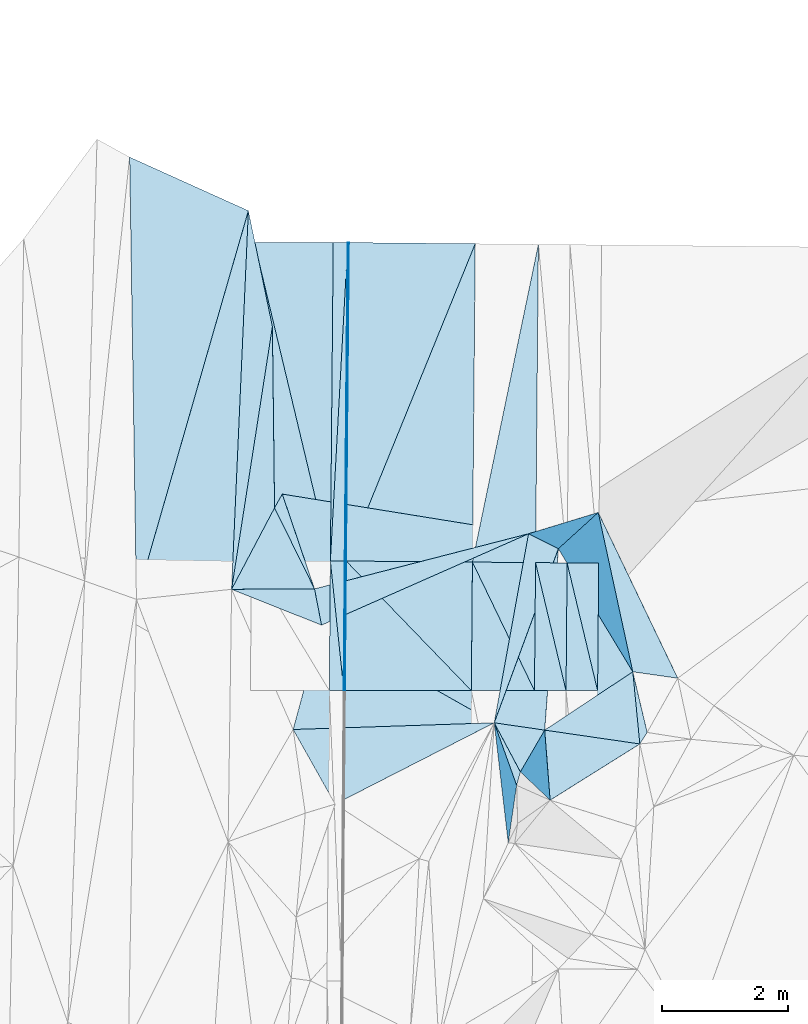
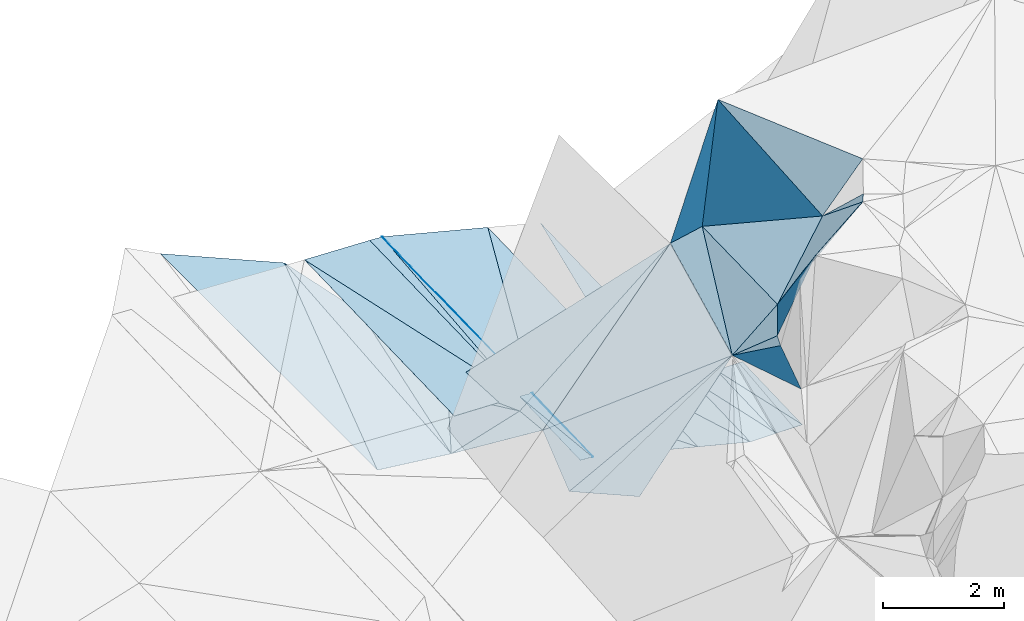
# One storey, part 161 of 275: 46 plates.
"""IFC2X3 building model written with IfcOpenShell, lengths in millimetres."""

from ifc_helpers import new_model, si_unit, frame, origin_with_axes, place, context, subcontext, project, spatial, polyline, outline, extrude, material, type_object, element, save


model = new_model("IFC2X3")

# Units and contexts
model_context = context("Model", 3, precision=1e-05, world=origin_with_axes())
body_context = subcontext(model_context, "Body", "Model", "MODEL_VIEW")
ifc_project = project(units=[si_unit("LENGTHUNIT", "METRE", prefix="MILLI"), si_unit("AREAUNIT", "SQUARE_METRE"), si_unit("VOLUMEUNIT", "CUBIC_METRE"), si_unit("MASSUNIT", "GRAM", prefix="KILO"), si_unit("TIMEUNIT", "SECOND"), si_unit("PLANEANGLEUNIT", "RADIAN"), si_unit("SOLIDANGLEUNIT", "STERADIAN"), si_unit("THERMODYNAMICTEMPERATUREUNIT", "DEGREE_CELSIUS"), si_unit("LUMINOUSINTENSITYUNIT", "LUMEN")], contexts=[model_context])

# Site, building, storey
site_placement = place(None, origin_with_axes())
site = spatial("IfcSite", under=ifc_project, at=site_placement, CompositionType="ELEMENT")
building_placement = place(site_placement, origin_with_axes())
building = spatial("IfcBuilding", under=site, at=building_placement, Name="Undefined", CompositionType="ELEMENT")
storey_placement = place(building_placement, origin_with_axes())
storey = spatial("IfcBuildingStorey", under=building, at=storey_placement, Name="Undefined", CompositionType="ELEMENT", Elevation=0.0)

# Plates
ifc_material = material()
plate_type_1 = type_object("IfcPlateType", PredefinedType="NOTDEFINED")
plate_1_placement = place(storey_placement, frame((-53921.4130209684, 132875.767032502, 43040.4130466603), z_axis=(-0.242290097947549, 0.0238708479118804, -0.969910145867407), x_axis=(-0.970181049799979, 0.000892282855675396, 0.242379731909076)))
element("IfcPlate", 1, at=plate_1_placement, inside=storey, type_object=plate_type_1, material=ifc_material, Name="00_PR", context=body_context, shape_type="SweptSolid", body=[
    extrude(outline(polyline([(0.0, 0.0), (2061.525390625, -3.63797880709171e-09), (2057.89990234375, 2051.69555664063), (0.0, 0.0)])), frame((-8.85201319254618e-08, 2.18876761149539e-07, -0.5000001331573), z_axis=(0.0, 0.0, 1.0), x_axis=(1.0, 0.0, 0.0)), (0.0, 0.0, 1.0), 1.0),
])
plate_type_2 = type_object("IfcPlateType", PredefinedType="NOTDEFINED")
plate_2_placement = place(storey_placement, frame((-55904.2060124232, 134928.710053341, 43586.2636953464), z_axis=(-0.0497725011782063, 0.0172078240274275, -0.998612331647625), x_axis=(0.00499603186977933, 0.999843346921011, 0.0169800260114044)))
element("IfcPlate", 2, at=plate_2_placement, inside=storey, type_object=plate_type_2, material=ifc_material, Name="00_PR", context=body_context, shape_type="SweptSolid", body=[
    extrude(outline(polyline([(0.0, 0.0), (5045.751953125, -6.52726157568395e-08), (5045.6474609375, 20.0242309570313), (0.0, 0.0)])), frame((-8.85201319254618e-08, 2.18876761149539e-07, -0.5000001331573), z_axis=(0.0, 0.0, 1.0), x_axis=(1.0, 0.0, 0.0)), (0.0, 0.0, 1.0), 1.0),
])
plate_3_placement = place(storey_placement, frame((-55921.3697174635, 132877.606016511, 43540.0707515838), z_axis=(-0.0497315401141636, 0.0229033836072573, -0.998499979437763), x_axis=(-0.00138182012259153, 0.999734497988441, 0.0230005240146595)))
element("IfcPlate", 3, at=plate_3_placement, inside=storey, type_object=plate_type_2, material=ifc_material, Name="00_PR", context=body_context, shape_type="SweptSolid", body=[
    extrude(outline(polyline([(0.0, 0.0), (2051.82275390625, -1.82699295692146e-08), (2051.60107421875, 20.0234661102295), (0.0, 0.0)])), frame((-8.85201319254618e-08, 2.18876761149539e-07, -0.5000001331573), z_axis=(0.0, 0.0, 1.0), x_axis=(1.0, 0.0, 0.0)), (0.0, 0.0, 1.0), 1.0),
])
plate_4_placement = place(storey_placement, frame((-55924.2049922256, 134928.881206525, 43587.2636961487), z_axis=(-0.0497854212460474, 0.0172078761853657, -0.998611686707372), x_axis=(0.00895964489837265, 0.99981902822702, 0.0167820010270476)))
element("IfcPlate", 4, at=plate_4_placement, inside=storey, type_object=plate_type_2, material=ifc_material, Name="00_PR", context=body_context, shape_type="SweptSolid", body=[
    extrude(outline(polyline([(0.0, 0.0), (5045.70361328125, -3.39423422701657e-08), (-0.00872510019689798, 20.0246906280518), (0.0, 0.0)])), frame((-8.85201319254618e-08, 2.18876761149539e-07, -0.5000001331573), z_axis=(0.0, 0.0, 1.0), x_axis=(1.0, 0.0, 0.0)), (0.0, 0.0, 1.0), 1.0),
])
plate_5_placement = place(storey_placement, frame((-55941.3701169843, 132877.624564946, 43541.0677525396), z_axis=(-0.0497529466740332, 0.0229033298257444, -0.998498914260874), x_axis=(0.00836568591627843, 0.999711519163658, 0.0225143010249118)))
element("IfcPlate", 5, at=plate_5_placement, inside=storey, type_object=plate_type_2, material=ifc_material, Name="00_PR", context=body_context, shape_type="SweptSolid", body=[
    extrude(outline(polyline([(0.0, 0.0), (2051.85131835938, 7.93079379945993e-10), (0.126321852207184, 20.0248374938965), (0.0, 0.0)])), frame((-8.85201319254618e-08, 2.18876761149539e-07, -0.5000001331573), z_axis=(0.0, 0.0, 1.0), x_axis=(1.0, 0.0, 0.0)), (0.0, 0.0, 1.0), 1.0),
])
plate_type_3 = type_object("IfcPlateType", PredefinedType="NOTDEFINED")
plate_6_placement = place(storey_placement, frame((-52904.4115996075, 134903.095372092, 42836.2780461026), z_axis=(-0.242282814206146, 0.0238821500295382, -0.969911687139771), x_axis=(-0.00836740889175489, -0.999711247153736, -0.0225257360092888)))
element("IfcPlate", 6, at=plate_6_placement, inside=storey, type_object=plate_type_3, material=ifc_material, Name="00_PR", context=body_context, shape_type="SweptSolid", body=[
    extrude(outline(polyline([(0.0, 0.0), (2028.8349609375, -1.53013388626277e-08), (-5.80120325088501, 1030.76013183594), (0.0, 0.0)])), frame((-8.85201319254618e-08, 2.18876761149539e-07, -0.5000001331573), z_axis=(0.0, 0.0, 1.0), x_axis=(1.0, 0.0, 0.0)), (0.0, 0.0, 1.0), 1.0),
])
plate_type_4 = type_object("IfcPlateType", PredefinedType="NOTDEFINED")
plate_7_placement = place(storey_placement, frame((-56108.9794554102, 139975.828901893, 43683.440374112), z_axis=(-0.0345822401341188, 0.0170818079940754, -0.999255863381827), x_axis=(-0.00895964489279158, -0.999819028227098, -0.0167820010254024)))
element("IfcPlate", 7, at=plate_7_placement, inside=storey, type_object=plate_type_4, material=ifc_material, Name="00_PR", context=body_context, shape_type="SweptSolid", body=[
    extrude(outline(polyline([(0.0, 0.0), (5045.89697265625, 2.19661160372198e-08), (9.51279067993164, 1250.75866699219), (0.0, 0.0)])), frame((-8.85201319254618e-08, 2.18876761149539e-07, -0.5000001331573), z_axis=(0.0, 0.0, 1.0), x_axis=(1.0, 0.0, 0.0)), (0.0, 0.0, 1.0), 1.0),
])
plate_type_5 = type_object("IfcPlateType", PredefinedType="NOTDEFINED")
plate_8_placement = place(storey_placement, frame((-51904.3262961077, 134894.556678768, 42836.2631288285), z_axis=(0.000192357398170822, 0.0225286831170885, -0.999746178505145), x_axis=(-0.00836798991196483, -0.99971115738236, -0.0225295039904336)))
element("IfcPlate", 8, at=plate_8_placement, inside=storey, type_object=plate_type_5, material=ifc_material, Name="00_PR", context=body_context, shape_type="SweptSolid", body=[
    extrude(outline(polyline([(0.0, 0.0), (2021.21618652344, -1.95432221516967e-08), (-0.0839325413107872, 500.000244140625), (0.0, 0.0)])), frame((-8.85201319254618e-08, 2.18876761149539e-07, -0.5000001331573), z_axis=(0.0, 0.0, 1.0), x_axis=(1.0, 0.0, 0.0)), (0.0, 0.0, 1.0), 1.0),
])
plate_9_placement = place(storey_placement, frame((-52404.308328989, 134898.825689368, 42836.2631288407), z_axis=(0.000192341308816795, 0.0225268031947438, -0.9997462208694), x_axis=(-0.0083675759069814, -0.999711203213438, -0.0225276239977039)))
element("IfcPlate", 9, at=plate_9_placement, inside=storey, type_object=plate_type_5, material=ifc_material, Name="00_PR", context=body_context, shape_type="SweptSolid", body=[
    extrude(outline(polyline([(0.0, 0.0), (2025.02490234375, -1.42608769237995e-08), (-0.0841391012072563, 500.000244140625), (0.0, 0.0)])), frame((-8.85201319254618e-08, 2.18876761149539e-07, -0.5000001331573), z_axis=(0.0, 0.0, 1.0), x_axis=(1.0, 0.0, 0.0)), (0.0, 0.0, 1.0), 1.0),
])
plate_type_6 = type_object("IfcPlateType", PredefinedType="NOTDEFINED")
plate_10_placement = place(storey_placement, frame((-55878.9972813765, 139973.671639461, 43671.9406962223), z_axis=(-0.0497854212460474, 0.0172078761853657, -0.998611686707372), x_axis=(-0.00895964489279158, -0.999819028227098, -0.0167820010254024)))
element("IfcPlate", 10, at=plate_10_placement, inside=storey, type_object=plate_type_6, material=ifc_material, Name="00_PR", context=body_context, shape_type="SweptSolid", body=[
    extrude(outline(polyline([(0.0, 0.0), (5045.70361328125, -3.39423422701657e-08), (5045.607421875, 230.287475585938), (0.0, 0.0)])), frame((-8.85201319254618e-08, 2.18876761149539e-07, -0.5000001331573), z_axis=(0.0, 0.0, 1.0), x_axis=(1.0, 0.0, 0.0)), (0.0, 0.0, 1.0), 1.0),
])
plate_11_placement = place(storey_placement, frame((-56154.1967670006, 134930.845211354, 43598.7636957895), z_axis=(-0.0497714340509185, 0.0172071230381387, -0.99861239691347), x_axis=(0.00895964489837265, 0.99981902822702, 0.0167820010270476)))
element("IfcPlate", 11, at=plate_11_placement, inside=storey, type_object=plate_type_6, material=ifc_material, Name="00_PR", context=body_context, shape_type="SweptSolid", body=[
    extrude(outline(polyline([(0.0, 0.0), (5045.89697265625, 2.19661160372198e-08), (5045.607421875, 230.287033081055), (0.0, 0.0)])), frame((-8.85201319254618e-08, 2.18876761149539e-07, -0.5000001331573), z_axis=(0.0, 0.0, 1.0), x_axis=(1.0, 0.0, 0.0)), (0.0, 0.0, 1.0), 1.0),
])
plate_type_7 = type_object("IfcPlateType", PredefinedType="NOTDEFINED")
plate_12_placement = place(storey_placement, frame((-56405.4393574782, 134486.97513791, 43659.5220884119), z_axis=(0.29267855635156, -0.0269160163758398, -0.955831988748243), x_axis=(-0.956205391673312, -0.00484916303644232, -0.292656342068191)))
element("IfcPlate", 12, at=plate_12_placement, inside=storey, type_object=plate_type_7, material=ifc_material, Name="00", context=body_context, shape_type="SweptSolid", body=[
    extrude(outline(polyline([(0.0, 0.0), (1373.62475585938, 3.34694050252438e-09), (666.448364257813, 1287.34094238281), (0.0, 0.0)])), frame((-8.85201319254618e-08, 2.18876761149539e-07, -0.5000001331573), z_axis=(0.0, 0.0, 1.0), x_axis=(1.0, 0.0, 0.0)), (0.0, 0.0, 1.0), 1.0),
])
plate_type_8 = type_object("IfcPlateType", PredefinedType="NOTDEFINED")
plate_13_placement = place(storey_placement, frame((-52859.2261846876, 139945.336646448, 42920.954995991), z_axis=(-0.242354222271301, 0.0184617411486156, -0.970012162326347), x_axis=(-0.00895975488317066, -0.999818885003066, -0.016790473002845)))
element("IfcPlate", 13, at=plate_13_placement, inside=storey, type_object=plate_type_8, material=ifc_material, Name="00_PR", context=body_context, shape_type="SweptSolid", body=[
    extrude(outline(polyline([(0.0, 0.0), (5043.1572265625, 7.13480403646827e-08), (5039.38134765625, 1030.76953125), (0.0, 0.0)])), frame((-8.85201319254618e-08, 2.18876761149539e-07, -0.5000001331573), z_axis=(0.0, 0.0, 1.0), x_axis=(1.0, 0.0, 0.0)), (0.0, 0.0, 1.0), 1.0),
])
plate_type_9 = type_object("IfcPlateType", PredefinedType="NOTDEFINED")
plate_14_placement = place(storey_placement, frame((-55924.2049667567, 134928.884053921, 43587.2637520365), z_axis=(-0.0497315401141636, 0.0229033836072573, -0.998499979437763), x_axis=(-0.00836568588378333, -0.999711519163901, -0.0225143010262109)))
element("IfcPlate", 14, at=plate_14_placement, inside=storey, type_object=plate_type_9, material=ifc_material, Name="00_PR", context=body_context, shape_type="SweptSolid", body=[
    extrude(outline(polyline([(0.0, 0.0), (2051.85131835938, 7.93079379945993e-10), (-0.298315227031708, 230.287292480469), (0.0, 0.0)])), frame((-8.85201319254618e-08, 2.18876761149539e-07, -0.5000001331573), z_axis=(0.0, 0.0, 1.0), x_axis=(1.0, 0.0, 0.0)), (0.0, 0.0, 1.0), 1.0),
])
plate_15_placement = place(storey_placement, frame((-56171.3751850407, 132877.835496, 43552.5297522885), z_axis=(-0.0497379128704129, 0.0229024672686787, -0.99849968303265), x_axis=(0.00836501392567888, 0.999711541024091, 0.0225135800187272)))
element("IfcPlate", 15, at=plate_15_placement, inside=storey, type_object=plate_type_9, material=ifc_material, Name="00_PR", context=body_context, shape_type="SweptSolid", body=[
    extrude(outline(polyline([(0.0, 0.0), (2053.60498046875, 1.96523615159094e-08), (1.455073595047, 230.285995483398), (0.0, 0.0)])), frame((-8.85201319254618e-08, 2.18876761149539e-07, -0.5000001331573), z_axis=(0.0, 0.0, 1.0), x_axis=(1.0, 0.0, 0.0)), (0.0, 0.0, 1.0), 1.0),
])
plate_type_10 = type_object("IfcPlateType", PredefinedType="NOTDEFINED")
plate_16_placement = place(storey_placement, frame((-52421.2528831777, 132874.38557646, 42790.6441287965), z_axis=(0.000184737649818864, 0.0225268668452634, -0.999746220869145), x_axis=(0.00836757589274174, 0.999711203213378, 0.0225276240056514)))
element("IfcPlate", 16, at=plate_16_placement, inside=storey, type_object=plate_type_10, material=ifc_material, Name="00_PR", context=body_context, shape_type="SweptSolid", body=[
    extrude(outline(polyline([(0.0, 0.0), (2025.02490234375, -1.42608769237995e-08), (3.72456526756287, 499.999420166016), (0.0, 0.0)])), frame((-8.85201319254618e-08, 2.18876761149539e-07, -0.5000001331573), z_axis=(0.0, 0.0, 1.0), x_axis=(1.0, 0.0, 0.0)), (0.0, 0.0, 1.0), 1.0),
])
plate_17_placement = place(storey_placement, frame((-52921.2664574846, 132874.845568885, 42790.5621287736), z_axis=(0.000184676063021724, 0.022524979296584, -0.999746263410092), x_axis=(0.00836740888687607, 0.9997112471538, 0.0225257360082723)))
element("IfcPlate", 17, at=plate_17_placement, inside=storey, type_object=plate_type_10, material=ifc_material, Name="00_PR", context=body_context, shape_type="SweptSolid", body=[
    extrude(outline(polyline([(0.0, 0.0), (2028.8349609375, -1.53013388626277e-08), (3.72580480575562, 499.999908447266), (0.0, 0.0)])), frame((-8.85201319254618e-08, 2.18876761149539e-07, -0.5000001331573), z_axis=(0.0, 0.0, 1.0), x_axis=(1.0, 0.0, 0.0)), (0.0, 0.0, 1.0), 1.0),
])
plate_type_11 = type_object("IfcPlateType", PredefinedType="NOTDEFINED")
plate_18_placement = place(storey_placement, frame((-53859.1819873665, 139954.719111887, 43170.9549940225), z_axis=(-0.242341293143886, 0.0184534773975507, -0.970015549777058), x_axis=(-0.375800488034076, -0.923552718411648, 0.0763175570088952)))
element("IfcPlate", 18, at=plate_18_placement, inside=storey, type_object=plate_type_11, material=ifc_material, Name="00_PR", context=body_context, shape_type="SweptSolid", body=[
    extrude(outline(polyline([(0.0, 0.0), (5442.03759765625, 5.18339220434427e-08), (772.396179199219, 1911.38903808594), (0.0, 0.0)])), frame((-8.85201319254618e-08, 2.18876761149539e-07, -0.5000001331573), z_axis=(0.0, 0.0, 1.0), x_axis=(1.0, 0.0, 0.0)), (0.0, 0.0, 1.0), 1.0),
])
plate_19_placement = place(storey_placement, frame((-53859.1819873665, 139954.719111887, 43170.9549940225), z_axis=(-0.242354256552694, 0.0184590281804045, -0.970012205391987), x_axis=(-0.00895979286870753, -0.999818931781245, -0.0167876670076637)))
element("IfcPlate", 19, at=plate_19_placement, inside=storey, type_object=plate_type_11, material=ifc_material, Name="00_PR", context=body_context, shape_type="SweptSolid", body=[
    extrude(outline(polyline([(0.0, 0.0), (5044.00048828125, 3.51283233612776e-08), (5036.44970703125, 2061.5390625), (0.0, 0.0)])), frame((-8.85201319254618e-08, 2.18876761149539e-07, -0.5000001331573), z_axis=(0.0, 0.0, 1.0), x_axis=(1.0, 0.0, 0.0)), (0.0, 0.0, 1.0), 1.0),
])
plate_type_12 = type_object("IfcPlateType", PredefinedType="NOTDEFINED")
plate_20_placement = place(storey_placement, frame((-55904.302267707, 134928.713389166, 43586.2780457261), z_axis=(-0.242282867316031, 0.0238782631497267, -0.96991176957189), x_axis=(0.970107128969726, -0.00828437587314537, -0.242535620968359)))
element("IfcPlate", 20, at=plate_20_placement, inside=storey, type_object=plate_type_12, material=ifc_material, Name="00_PR", context=body_context, shape_type="SweptSolid", body=[
    extrude(outline(polyline([(0.0, 0.0), (2061.552734375, -7.5924617704004e-09), (2073.01416015625, 2036.42321777344), (0.0, 0.0)])), frame((-8.85201319254618e-08, 2.18876761149539e-07, -0.5000001331573), z_axis=(0.0, 0.0, 1.0), x_axis=(1.0, 0.0, 0.0)), (0.0, 0.0, 1.0), 1.0),
])
plate_type_13 = type_object("IfcPlateType", PredefinedType="NOTDEFINED")
plate_21_placement = place(storey_placement, frame((-53921.4130209684, 132875.767032502, 43040.4130466603), z_axis=(-0.242290291642515, 0.0238782835789022, -0.969909914450363), x_axis=(0.00836642688511088, 0.999711340108892, 0.022521975021303)))
element("IfcPlate", 21, at=plate_21_placement, inside=storey, type_object=plate_type_13, material=ifc_material, Name="00_PR", context=body_context, shape_type="SweptSolid", body=[
    extrude(outline(polyline([(0.0, 0.0), (2036.45556640625, -1.68802216649055e-09), (1.81930899620056, 1030.76000976563), (0.0, 0.0)])), frame((-8.85201319254618e-08, 2.18876761149539e-07, -0.5000001331573), z_axis=(0.0, 0.0, 1.0), x_axis=(1.0, 0.0, 0.0)), (0.0, 0.0, 1.0), 1.0),
])
plate_type_14 = type_object("IfcPlateType", PredefinedType="NOTDEFINED")
plate_22_placement = place(storey_placement, frame((-57404.2935749814, 134923.985691005, 43641.9483743452), z_axis=(-0.0346130658529225, 0.0170744240414671, -0.999254922287558), x_axis=(0.00895746995109016, 0.999819185520099, 0.0167737890174219)))
element("IfcPlate", 22, at=plate_22_placement, inside=storey, type_object=plate_type_14, material=ifc_material, Name="00_PR", context=body_context, shape_type="SweptSolid", body=[
    extrude(outline(polyline([(0.0, 0.0), (5053.71826171875, -5.00876922160387e-08), (17.3316078186035, 1250.74877929688), (0.0, 0.0)])), frame((-8.85201319254618e-08, 2.18876761149539e-07, -0.5000001331573), z_axis=(0.0, 0.0, 1.0), x_axis=(1.0, 0.0, 0.0)), (0.0, 0.0, 1.0), 1.0),
])
plate_type_15 = type_object("IfcPlateType", PredefinedType="NOTDEFINED")
plate_23_placement = place(storey_placement, frame((-52759.4480902491, 132250.070475777, 45899.6500832261), z_axis=(0.705505224369645, -0.111708546354468, -0.6998453965402), x_axis=(-0.692641011922544, 0.100374453991266, -0.714264235132118)))
element("IfcPlate", 23, at=plate_23_placement, inside=storey, type_object=plate_type_15, material=ifc_material, Name="00", context=body_context, shape_type="SweptSolid", body=[
    extrude(outline(polyline([(0.0, 0.0), (1153.63464355469, -7.13043846189976e-10), (309.612731933594, 2874.53295898438), (0.0, 0.0)])), frame((-8.85201319254618e-08, 2.18876761149539e-07, -0.5000001331573), z_axis=(0.0, 0.0, 1.0), x_axis=(1.0, 0.0, 0.0)), (0.0, 0.0, 1.0), 1.0),
])
plate_type_16 = type_object("IfcPlateType", PredefinedType="NOTDEFINED")
plate_24_placement = place(storey_placement, frame((-51911.0034304418, 135697.942403331, 47659.8046486892), z_axis=(0.610772609463674, 0.688693798528745, -0.390714309178692), x_axis=(-0.290467836710068, -0.264165947931313, -0.919698204733773)))
element("IfcPlate", 24, at=plate_24_placement, inside=storey, type_object=plate_type_16, material=ifc_material, Name="00", context=body_context, shape_type="SweptSolid", body=[
    extrude(outline(polyline([(0.0, 0.0), (2174.62646484375, -1.71712599694729e-09), (2543.42529296875, 495.729064941406), (0.0, 0.0)])), frame((-8.85201319254618e-08, 2.18876761149539e-07, -0.5000001331573), z_axis=(0.0, 0.0, 1.0), x_axis=(1.0, 0.0, 0.0)), (0.0, 0.0, 1.0), 1.0),
])
plate_type_17 = type_object("IfcPlateType", PredefinedType="NOTDEFINED")
plate_25_placement = place(storey_placement, frame((-53336.5333643081, 130464.251713005, 45469.7728505699), z_axis=(0.89078875184682, 0.00980529037591187, -0.454311848694076), x_axis=(-0.113509663064056, 0.972875490355746, -0.201565961055314)))
element("IfcPlate", 25, at=plate_25_placement, inside=storey, type_object=plate_type_17, material=ifc_material, Name="00", context=body_context, shape_type="SweptSolid", body=[
    extrude(outline(polyline([(0.0, 0.0), (1954.69506835938, -1.17579475045204e-08), (815.288269042969, 512.059631347656), (0.0, 0.0)])), frame((-8.85201319254618e-08, 2.18876761149539e-07, -0.5000001331573), z_axis=(0.0, 0.0, 1.0), x_axis=(1.0, 0.0, 0.0)), (0.0, 0.0, 1.0), 1.0),
])
plate_26_placement = place(storey_placement, frame((-57718.9099367172, 134480.421063816, 43257.5301605714), z_axis=(0.286646956485394, 0.18671907563704, -0.939664572669902), x_axis=(0.956205391658711, 0.00484916362865737, 0.292656342106084)))
element("IfcPlate", 26, at=plate_26_placement, inside=storey, type_object=plate_type_17, material=ifc_material, Name="00", context=body_context, shape_type="SweptSolid", body=[
    extrude(outline(polyline([(0.0, 0.0), (1373.62475585938, 3.34694050252438e-09), (1454.11987304688, 584.568664550781), (0.0, 0.0)])), frame((-8.85201319254618e-08, 2.18876761149539e-07, -0.5000001331573), z_axis=(0.0, 0.0, 1.0), x_axis=(1.0, 0.0, 0.0)), (0.0, 0.0, 1.0), 1.0),
])
plate_type_18 = type_object("IfcPlateType", PredefinedType="NOTDEFINED")
plate_27_placement = place(storey_placement, frame((-56079.0226590948, 131077.805260528, 43879.5524380044), z_axis=(0.444172615284776, -0.0379666098570675, -0.89513642779581), x_axis=(-0.471973652905792, 0.839315956800456, -0.269795469982167)))
element("IfcPlate", 27, at=plate_27_placement, inside=storey, type_object=plate_type_18, material=ifc_material, Name="00", context=body_context, shape_type="SweptSolid", body=[
    extrude(outline(polyline([(0.0, 0.0), (1408.47436523438, -1.60798663273454e-09), (-431.111846923828, 3042.38647460938), (0.0, 0.0)])), frame((-8.85201319254618e-08, 2.18876761149539e-07, -0.5000001331573), z_axis=(0.0, 0.0, 1.0), x_axis=(1.0, 0.0, 0.0)), (0.0, 0.0, 1.0), 1.0),
])
plate_type_19 = type_object("IfcPlateType", PredefinedType="NOTDEFINED")
plate_28_placement = place(storey_placement, frame((-53558.4469816887, 132365.874571017, 45075.7156685813), z_axis=(0.817124312413993, -0.0944267748380786, -0.568675164092505), x_axis=(0.362933269042264, -0.682165753203995, 0.634767144217407)))
element("IfcPlate", 28, at=plate_28_placement, inside=storey, type_object=plate_type_19, material=ifc_material, Name="00", context=body_context, shape_type="SweptSolid", body=[
    extrude(outline(polyline([(0.0, 0.0), (1140.57568359375, -1.81898940354586e-09), (1231.99450683594, 206.500885009766), (0.0, 0.0)])), frame((-8.85201319254618e-08, 2.18876761149539e-07, -0.5000001331573), z_axis=(0.0, 0.0, 1.0), x_axis=(1.0, 0.0, 0.0)), (0.0, 0.0, 1.0), 1.0),
])
plate_type_20 = type_object("IfcPlateType", PredefinedType="NOTDEFINED")
plate_29_placement = place(storey_placement, frame((-53144.5687033082, 131587.717805274, 45799.6561622169), z_axis=(0.667919947880149, -0.284550911596233, -0.687687226821563), x_axis=(-0.362933269046718, 0.682165753206904, -0.634767144211734)))
element("IfcPlate", 29, at=plate_29_placement, inside=storey, type_object=plate_type_20, material=ifc_material, Name="00", context=body_context, shape_type="SweptSolid", body=[
    extrude(outline(polyline([(0.0, 0.0), (1140.57568359375, -1.81898940354586e-09), (248.532379150391, 731.526916503906), (0.0, 0.0)])), frame((-8.85201319254618e-08, 2.18876761149539e-07, -0.5000001331573), z_axis=(0.0, 0.0, 1.0), x_axis=(1.0, 0.0, 0.0)), (0.0, 0.0, 1.0), 1.0),
])
plate_30_placement = place(storey_placement, frame((-52759.3836052857, 132249.909350819, 45899.8302008077), z_axis=(0.834472874496438, -0.433958390683695, -0.339610272054409), x_axis=(0.0436475598895498, -0.562309119820977, 0.825774390667237)))
element("IfcPlate", 30, at=plate_30_placement, inside=storey, type_object=plate_type_20, material=ifc_material, Name="00", context=body_context, shape_type="SweptSolid", body=[
    extrude(outline(polyline([(0.0, 0.0), (1973.90478515625, -4.51109372079372e-10), (273.012145996094, 722.747802734375), (0.0, 0.0)])), frame((-8.85201319254618e-08, 2.18876761149539e-07, -0.5000001331573), z_axis=(0.0, 0.0, 1.0), x_axis=(1.0, 0.0, 0.0)), (0.0, 0.0, 1.0), 1.0),
])
plate_type_21 = type_object("IfcPlateType", PredefinedType="NOTDEFINED")
plate_31_placement = place(storey_placement, frame((-51363.5988160065, 133173.156173366, 46639.6864676096), z_axis=(0.632839349365116, -0.454190387850623, -0.627076908743446), x_axis=(0.075134868943394, -0.770036088963479, 0.633560709926592)))
element("IfcPlate", 31, at=plate_31_placement, inside=storey, type_object=plate_type_21, material=ifc_material, Name="00", context=body_context, shape_type="SweptSolid", body=[
    extrude(outline(polyline([(0.0, 0.0), (1483.67785644531, -7.11588654667139e-09), (137.226547241211, 1824.73803710938), (0.0, 0.0)])), frame((-8.85201319254618e-08, 2.18876761149539e-07, -0.5000001331573), z_axis=(0.0, 0.0, 1.0), x_axis=(1.0, 0.0, 0.0)), (0.0, 0.0, 1.0), 1.0),
])
plate_type_22 = type_object("IfcPlateType", PredefinedType="NOTDEFINED")
plate_32_placement = place(storey_placement, frame((-51363.4824659686, 133173.551922721, 46639.8148832223), z_axis=(0.865530174705086, 0.337307126633336, -0.370245079639618), x_axis=(-0.475358745008853, 0.78608190908508, -0.395106689076211)))
element("IfcPlate", 32, at=plate_32_placement, inside=storey, type_object=plate_type_22, material=ifc_material, Name="00", context=body_context, shape_type="SweptSolid", body=[
    extrude(outline(polyline([(0.0, 0.0), (2480.3427734375, -2.50729499384761e-08), (1841.43908691406, 2078.65380859375), (0.0, 0.0)])), frame((-8.85201319254618e-08, 2.18876761149539e-07, -0.5000001331573), z_axis=(0.0, 0.0, 1.0), x_axis=(1.0, 0.0, 0.0)), (0.0, 0.0, 1.0), 1.0),
])
plate_type_23 = type_object("IfcPlateType", PredefinedType="NOTDEFINED")
plate_33_placement = place(storey_placement, frame((-52542.707147108, 135123.080787292, 45659.5769046687), z_axis=(0.521377054707337, -0.110037994947695, -0.846201871005137), x_axis=(0.475358745020277, -0.786081909075532, 0.39510668908146)))
element("IfcPlate", 33, at=plate_33_placement, inside=storey, type_object=plate_type_23, material=ifc_material, Name="00", context=body_context, shape_type="SweptSolid", body=[
    extrude(outline(polyline([(0.0, 0.0), (2480.3427734375, -2.50729499384761e-08), (2250.1728515625, 1815.35717773438), (0.0, 0.0)])), frame((-8.85201319254618e-08, 2.18876761149539e-07, -0.5000001331573), z_axis=(0.0, 0.0, 1.0), x_axis=(1.0, 0.0, 0.0)), (0.0, 0.0, 1.0), 1.0),
])
plate_type_24 = type_object("IfcPlateType", PredefinedType="NOTDEFINED")
plate_34_placement = place(storey_placement, frame((-56293.8124024508, 133913.198569466, 43579.5513476646), z_axis=(0.392744751256789, 0.201443150279047, -0.897313890211166), x_axis=(-0.189086264046638, 0.972556498925378, 0.135573748000477)))
element("IfcPlate", 34, at=plate_34_placement, inside=storey, type_object=plate_type_24, material=ifc_material, Name="00", context=body_context, shape_type="SweptSolid", body=[
    extrude(outline(polyline([(0.0, 0.0), (590.084716796875, 6.91215973347425e-10), (1026.25939941406, 3858.68530273438), (0.0, 0.0)])), frame((-8.85201319254618e-08, 2.18876761149539e-07, -0.5000001331573), z_axis=(0.0, 0.0, 1.0), x_axis=(1.0, 0.0, 0.0)), (0.0, 0.0, 1.0), 1.0),
])
plate_type_25 = type_object("IfcPlateType", PredefinedType="NOTDEFINED")
plate_35_placement = place(storey_placement, frame((-57038.4927824718, 135770.621801084, 43429.5338245627), z_axis=(0.361360744948868, 0.0111640165545904, -0.932359253048077), x_axis=(0.479581975871122, 0.855300876873761, 0.196116135079516)))
element("IfcPlate", 35, at=plate_35_placement, inside=storey, type_object=plate_type_25, material=ifc_material, Name="00", context=body_context, shape_type="SweptSolid", body=[
    extrude(outline(polyline([(0.0, 0.0), (254.950973510742, -1.01863406598568e-10), (-749.163635253906, 1241.029296875), (0.0, 0.0)])), frame((-8.85201319254618e-08, 2.18876761149539e-07, -0.5000001331573), z_axis=(0.0, 0.0, 1.0), x_axis=(1.0, 0.0, 0.0)), (0.0, 0.0, 1.0), 1.0),
])
plate_type_26 = type_object("IfcPlateType", PredefinedType="NOTDEFINED")
plate_36_placement = place(storey_placement, frame((-57718.9213841328, 134480.322505479, 43257.5176926391), z_axis=(0.263431102879203, -0.0103217245249993, -0.964622991659787), x_axis=(0.153407682049592, 0.987666317497972, 0.0313261610825145)))
element("IfcPlate", 36, at=plate_36_placement, inside=storey, type_object=plate_type_26, material=ifc_material, Name="00", context=body_context, shape_type="SweptSolid", body=[
    extrude(outline(polyline([(0.0, 0.0), (4213.73046875, -5.67379174754024e-08), (1384.13806152344, 491.433319091797), (0.0, 0.0)])), frame((-8.85201319254618e-08, 2.18876761149539e-07, -0.5000001331573), z_axis=(0.0, 0.0, 1.0), x_axis=(1.0, 0.0, 0.0)), (0.0, 0.0, 1.0), 1.0),
])
plate_type_27 = type_object("IfcPlateType", PredefinedType="NOTDEFINED")
plate_37_placement = place(storey_placement, frame((-53015.0100406094, 135360.431641711, 45339.5602983889), z_axis=(0.475976693231241, -0.00887604625434572, -0.879413101621498), x_axis=(-0.177946976958701, -0.98023805008268, -0.0864189710732837)))
element("IfcPlate", 37, at=plate_37_placement, inside=storey, type_object=plate_type_27, material=ifc_material, Name="00", context=body_context, shape_type="SweptSolid", body=[
    extrude(outline(polyline([(0.0, 0.0), (3054.884765625, -3.01370164379478e-08), (2154.27905273438, 3361.80639648438), (0.0, 0.0)])), frame((-8.85201319254618e-08, 2.18876761149539e-07, -0.5000001331573), z_axis=(0.0, 0.0, 1.0), x_axis=(1.0, 0.0, 0.0)), (0.0, 0.0, 1.0), 1.0),
])
plate_type_28 = type_object("IfcPlateType", PredefinedType="NOTDEFINED")
plate_38_placement = place(storey_placement, frame((-51910.9262482838, 135697.786491821, 47659.7389730699), z_axis=(0.765120784443047, 0.376880682610168, -0.522064302829211), x_axis=(0.432359895177895, -0.901537611257099, -0.0171713869738053)))
element("IfcPlate", 38, at=plate_38_placement, inside=storey, type_object=plate_type_28, material=ifc_material, Name="00", context=body_context, shape_type="SweptSolid", body=[
    extrude(outline(polyline([(0.0, 0.0), (2911.82080078125, 1.94559106603265e-08), (2529.8603515625, 1145.21020507813), (0.0, 0.0)])), frame((-8.85201319254618e-08, 2.18876761149539e-07, -0.5000001331573), z_axis=(0.0, 0.0, 1.0), x_axis=(1.0, 0.0, 0.0)), (0.0, 0.0, 1.0), 1.0),
])
plate_type_29 = type_object("IfcPlateType", PredefinedType="NOTDEFINED")
plate_39_placement = place(storey_placement, frame((-52759.5666282128, 132249.767051238, 45899.7429762247), z_axis=(0.468427093111414, -0.718554716649873, -0.51405756255444), x_axis=(0.664700583009774, -0.0966731260139584, 0.740828888241513)))
element("IfcPlate", 39, at=plate_39_placement, inside=storey, type_object=plate_type_29, material=ifc_material, Name="00", context=body_context, shape_type="SweptSolid", body=[
    extrude(outline(polyline([(0.0, 0.0), (2267.73022460938, 4.36557456851006e-10), (1372.12097167969, 1419.00817871094), (0.0, 0.0)])), frame((-8.85201319254618e-08, 2.18876761149539e-07, -0.5000001331573), z_axis=(0.0, 0.0, 1.0), x_axis=(1.0, 0.0, 0.0)), (0.0, 0.0, 1.0), 1.0),
])
plate_type_30 = type_object("IfcPlateType", PredefinedType="NOTDEFINED")
plate_40_placement = place(storey_placement, frame((-51363.5657990484, 133173.1770006, 46639.7078640539), z_axis=(0.6988759336566, -0.412536914732562, -0.584282229182572), x_axis=(0.166168407862981, -0.700899427878613, 0.693633946853609)))
element("IfcPlate", 40, at=plate_40_placement, inside=storey, type_object=plate_type_30, material=ifc_material, Name="00", context=body_context, shape_type="SweptSolid", body=[
    extrude(outline(polyline([(0.0, 0.0), (1369.59851074219, 1.02809281088412e-08), (1471.30712890625, 191.194534301758), (0.0, 0.0)])), frame((-8.85201319254618e-08, 2.18876761149539e-07, -0.5000001331573), z_axis=(0.0, 0.0, 1.0), x_axis=(1.0, 0.0, 0.0)), (0.0, 0.0, 1.0), 1.0),
])
plate_type_31 = type_object("IfcPlateType", PredefinedType="NOTDEFINED")
plate_41_placement = place(storey_placement, frame((-53558.5797776496, 132365.908473267, 45075.5831397759), z_axis=(0.551530367586048, -0.0266191204929953, -0.833729977903265), x_axis=(0.177946976964179, 0.980238050081093, 0.0864189710800014)))
element("IfcPlate", 41, at=plate_41_placement, inside=storey, type_object=plate_type_31, material=ifc_material, Name="00", context=body_context, shape_type="SweptSolid", body=[
    extrude(outline(polyline([(0.0, 0.0), (3054.884765625, -3.01370164379478e-08), (2933.96899414063, 605.920227050781), (0.0, 0.0)])), frame((-8.85201319254618e-08, 2.18876761149539e-07, -0.5000001331573), z_axis=(0.0, 0.0, 1.0), x_axis=(1.0, 0.0, 0.0)), (0.0, 0.0, 1.0), 1.0),
])
plate_type_32 = type_object("IfcPlateType", PredefinedType="NOTDEFINED")
plate_42_placement = place(storey_placement, frame((-57719.0125243869, 134480.337160799, 43257.5017447221), z_axis=(0.0811670774964299, 0.0189998115206925, -0.996519399054964), x_axis=(0.0443060149630219, 0.99876118039373, 0.0226513040821213)))
element("IfcPlate", 42, at=plate_42_placement, inside=storey, type_object=plate_type_32, material=ifc_material, Name="00", context=body_context, shape_type="SweptSolid", body=[
    extrude(outline(polyline([(0.0, 0.0), (6004.0693359375, -4.79994923807681e-08), (4188.234375, 462.837799072266), (0.0, 0.0)])), frame((-8.85201319254618e-08, 2.18876761149539e-07, -0.5000001331573), z_axis=(0.0, 0.0, 1.0), x_axis=(1.0, 0.0, 0.0)), (0.0, 0.0, 1.0), 1.0),
])
plate_type_33 = type_object("IfcPlateType", PredefinedType="NOTDEFINED")
plate_43_placement = place(storey_placement, frame((-53015.0305379818, 135360.456254479, 45339.550300451), z_axis=(0.435295636034744, 0.0402661679543256, -0.899386649315733), x_axis=(-0.873065050826355, -0.224926408581499, -0.432626314211471)))
element("IfcPlate", 43, at=plate_43_placement, inside=storey, type_object=plate_type_33, material=ifc_material, Name="00", context=body_context, shape_type="SweptSolid", body=[
    extrude(outline(polyline([(0.0, 0.0), (3883.25903320313, 5.23868948221207e-09), (4069.33984375, 1585.48852539063), (0.0, 0.0)])), frame((-8.85201319254618e-08, 2.18876761149539e-07, -0.5000001331573), z_axis=(0.0, 0.0, 1.0), x_axis=(1.0, 0.0, 0.0)), (0.0, 0.0, 1.0), 1.0),
])
plate_type_34 = type_object("IfcPlateType", PredefinedType="NOTDEFINED")
plate_44_placement = place(storey_placement, frame((-57453.1182117831, 140476.9700476, 43393.506774397), z_axis=(-0.162674965734734, 0.0218666764687145, -0.986437379656416), x_axis=(-0.276750169231695, -0.9606334797093, 0.0243446398993858)))
element("IfcPlate", 44, at=plate_44_placement, inside=storey, type_object=plate_type_34, material=ifc_material, Name="00", context=body_context, shape_type="SweptSolid", body=[
    extrude(outline(polyline([(0.0, 0.0), (6407.9814453125, 5.22559275850654e-08), (-287.003021240234, 2069.87158203125), (0.0, 0.0)])), frame((-8.85201319254618e-08, 2.18876761149539e-07, -0.5000001331573), z_axis=(0.0, 0.0, 1.0), x_axis=(1.0, 0.0, 0.0)), (0.0, 0.0, 1.0), 1.0),
])
plate_type_35 = type_object("IfcPlateType", PredefinedType="NOTDEFINED")
plate_45_placement = place(storey_placement, frame((-57453.1334797851, 140476.974525992, 43393.5096572983), z_axis=(-0.193219651999856, 0.0308124540002058, -0.98067158557773), x_axis=(-0.0443060143573864, -0.998761180421436, -0.0226513040450801)))
element("IfcPlate", 45, at=plate_45_placement, inside=storey, type_object=plate_type_35, material=ifc_material, Name="00", context=body_context, shape_type="SweptSolid", body=[
    extrude(outline(polyline([(0.0, 0.0), (6004.0693359375, -4.79994923807681e-08), (6223.134765625, 1528.01159667969), (0.0, 0.0)])), frame((-8.85201319254618e-08, 2.18876761149539e-07, -0.5000001331573), z_axis=(0.0, 0.0, 1.0), x_axis=(1.0, 0.0, 0.0)), (0.0, 0.0, 1.0), 1.0),
])
plate_type_36 = type_object("IfcPlateType", PredefinedType="NOTDEFINED")
plate_46_placement = place(storey_placement, frame((-53558.6335875432, 132365.882958782, 45075.5537210019), z_axis=(0.444212177742617, -0.0777266886269299, -0.892543614071746), x_axis=(-0.895887150859421, -0.0297984405614524, -0.443281249169299)))
element("IfcPlate", 46, at=plate_46_placement, inside=storey, type_object=plate_type_36, material=ifc_material, Name="00", context=body_context, shape_type="SweptSolid", body=[
    extrude(outline(polyline([(0.0, 0.0), (3555.30493164063, 1.44063960760832e-09), (3067.43383789063, 1644.28771972656), (0.0, 0.0)])), frame((-8.85201319254618e-08, 2.18876761149539e-07, -0.5000001331573), z_axis=(0.0, 0.0, 1.0), x_axis=(1.0, 0.0, 0.0)), (0.0, 0.0, 1.0), 1.0),
])

save(model, "model.ifc")
